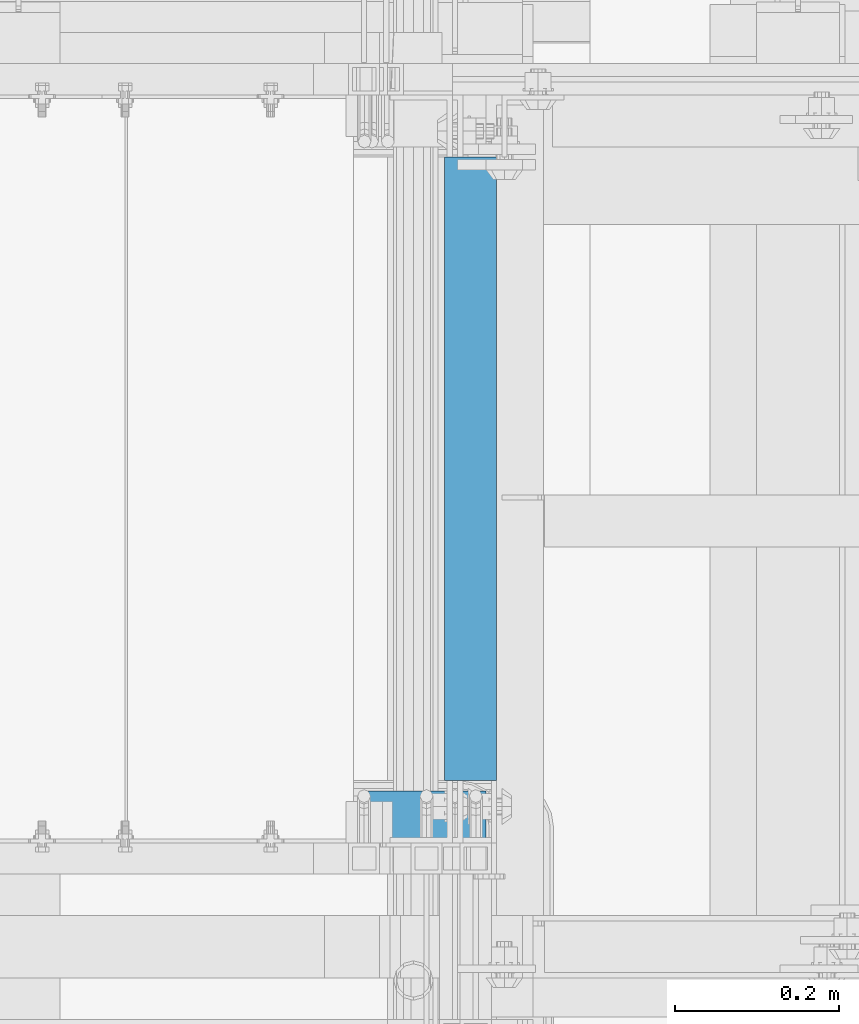
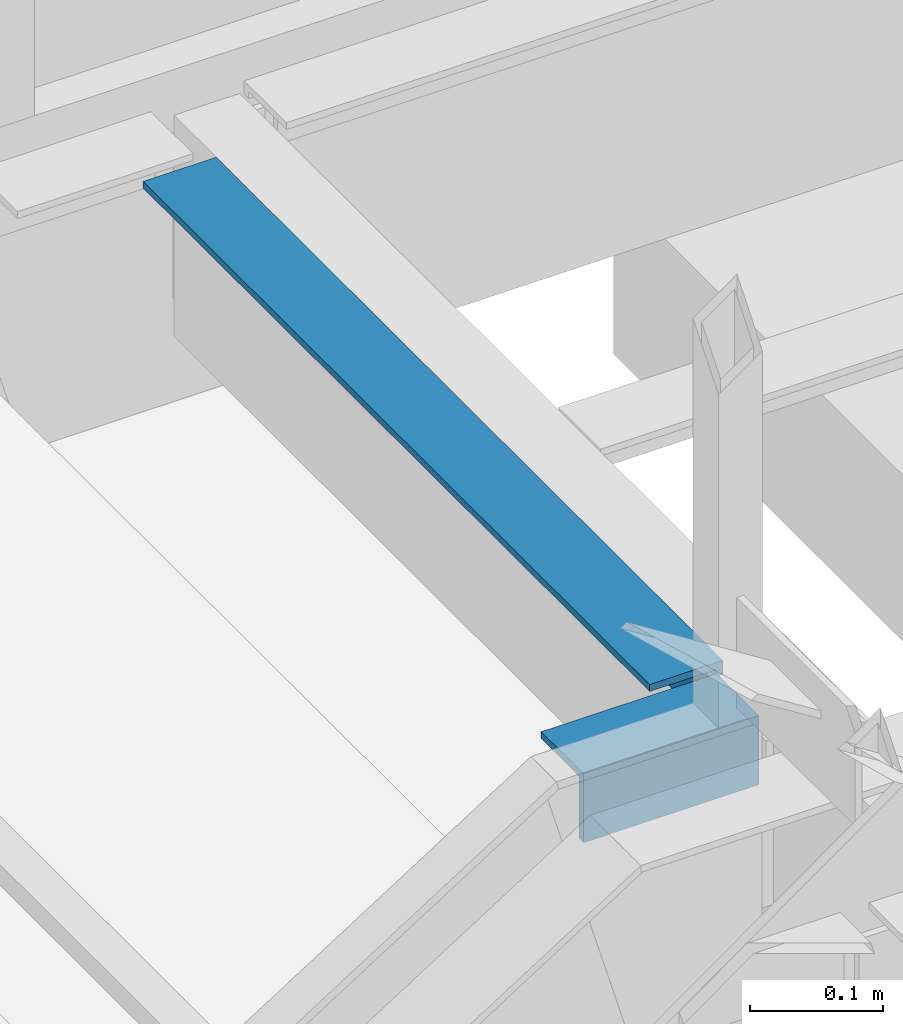
# One storey, part 1195 of 1876: 2 beams, 2 elements without a shape of their own.
"""IFC2X3 building model written with IfcOpenShell, lengths in millimetres."""

import ifcopenshell
import ifcopenshell.guid

model = None  # the IFC model being written
_history = None  # IfcOwnerHistory: only IFC2X3 demands one
_inside = {}  # id of a spatial element -> (the spatial element, [elements in it])
_under = {}  # id of a project, library or spatial element -> (it, [spatial elements below it])
_declared = {}  # id of a project -> (the project, [libraries it declares])
_typed = {}  # id of a type object -> (the type object, [elements of that type])
_made_of = {}  # id of a material, layer set ... -> (it, [elements and type objects made of it])


def new_model(schema):
    """Start an empty IFC model of exactly this schema.

    Asked for "IFC4X3", IfcOpenShell would pick the latest addendum, in which some entities
    have other attributes; the version numbers below select the first issue.
    IFC2X3 requires an IfcOwnerHistory on every rooted entity: one is made here for all.
    """
    global model, _history
    if schema == "IFC4X3":
        model = ifcopenshell.file(schema_version=(4, 3, 0, 0))
    else:
        model = ifcopenshell.file(schema=schema)
    _inside.clear()
    _under.clear()
    _declared.clear()
    _typed.clear()
    _made_of.clear()
    _history = None
    if model.schema == "IFC2X3":
        org = make("IfcOrganization", Name="unknown")
        user = make(
            "IfcPersonAndOrganization",
            ThePerson=make("IfcPerson", FamilyName="unknown"),
            TheOrganization=org,
        )
        app = make(
            "IfcApplication",
            ApplicationDeveloper=org,
            Version="unknown",
            ApplicationFullName="unknown",
            ApplicationIdentifier="unknown",
        )
        _history = make(
            "IfcOwnerHistory",
            OwningUser=user,
            OwningApplication=app,
            ChangeAction="ADDED",
            CreationDate=0,
        )
    return model


def make(cls, **values):
    """One entity of the class cls with the attributes given. An attribute that is None is left unset."""
    return model.create_entity(
        cls, **{name: value for name, value in values.items() if value is not None}
    )


def rooted(cls, **values):
    """An entity with a GlobalId (a new one), such as an element, a storey or a relation."""
    return make(cls, GlobalId=ifcopenshell.guid.new(), OwnerHistory=_history, **values)


def si_unit(unit_type, name, prefix=None):
    """IfcSIUnit, for example si_unit("LENGTHUNIT", "METRE", prefix="MILLI")."""
    return make("IfcSIUnit", UnitType=unit_type, Prefix=prefix, Name=name)


def assignment(units):
    """IfcUnitAssignment: the units of a project."""
    return None if units is None else make("IfcUnitAssignment", Units=units)


def point(xyz):
    """IfcCartesianPoint."""
    return None if xyz is None else make("IfcCartesianPoint", Coordinates=xyz)


def direction(xyz):
    """IfcDirection."""
    return None if xyz is None else make("IfcDirection", DirectionRatios=xyz)


def frame(location, z_axis=None, x_axis=None):
    """IfcAxis2Placement3D, a coordinate frame: its origin and axes. An axis left out is left unset."""
    return make(
        "IfcAxis2Placement3D",
        Location=point(location),
        Axis=direction(z_axis),
        RefDirection=direction(x_axis),
    )


def origin_with_axes():
    """The frame at (0, 0, 0) with the z axis (0, 0, 1) and the x axis (1, 0, 0) written out."""
    return frame((0.0, 0.0, 0.0), z_axis=(0.0, 0.0, 1.0), x_axis=(1.0, 0.0, 0.0))


def place(relative_to, where):
    """IfcLocalPlacement: puts the frame where relative to a parent placement (None: the world)."""
    return make(
        "IfcLocalPlacement", PlacementRelTo=relative_to, RelativePlacement=where
    )


def context(
    kind, dimensions, precision=None, world=None, true_north=None, identifier=None
):
    """IfcGeometricRepresentationContext, for example the 3D "Model" context."""
    return make(
        "IfcGeometricRepresentationContext",
        ContextIdentifier=identifier,
        ContextType=kind,
        CoordinateSpaceDimension=dimensions,
        Precision=precision,
        WorldCoordinateSystem=world,
        TrueNorth=true_north,
    )


def subcontext(parent, identifier, kind, view, scale=None):
    """IfcGeometricRepresentationSubContext, for example "Body" below "Model"."""
    return make(
        "IfcGeometricRepresentationSubContext",
        ContextIdentifier=identifier,
        ContextType=kind,
        ParentContext=parent,
        TargetScale=scale,
        TargetView=view,
    )


def project(units=None, contexts=None):
    """IfcProject with its units and contexts."""
    return rooted(
        "IfcProject",
        Name="project",
        RepresentationContexts=contexts,
        UnitsInContext=assignment(units),
    )


def spatial(cls, under=None, at=None, **own):
    """A site, building, storey or space (cls), placed at a placement, below another one or the project."""
    s = rooted(cls, ObjectPlacement=at, **own)
    if under is not None:
        _under.setdefault(under.id(), (under, []))[1].append(s)
    return s


def faces_of(points, faces, orient=None, outer=None):
    """IfcFace entities. A face is a list of loops; a loop is a list of indices into points, from 0.

    orient and outer hold one flag for each loop. By default every Orientation is true, the
    first loop of a face is its IfcFaceOuterBound and the others are IfcFaceBound.
    """
    made = []
    for i, loops in enumerate(faces):
        bounds = []
        for j, loop in enumerate(loops):
            is_outer = j == 0 if outer is None else outer[i][j]
            bounds.append(
                make(
                    "IfcFaceOuterBound" if is_outer else "IfcFaceBound",
                    Bound=make("IfcPolyLoop", Polygon=[points[k] for k in loop]),
                    Orientation=True if orient is None else orient[i][j],
                )
            )
        made.append(make("IfcFace", Bounds=bounds))
    return made


def faceted_brep(points, faces, orient=None, outer=None, voids=None):
    """IfcFacetedBrep: a solid bounded by flat faces; with voids (closed shells), ...WithVoids."""
    shared = [point(p) for p in points]
    hull = make("IfcClosedShell", CfsFaces=faces_of(shared, faces, orient, outer))
    if voids is None:
        return make("IfcFacetedBrep", Outer=hull)
    return make(
        "IfcFacetedBrepWithVoids",
        Outer=hull,
        Voids=[
            make(cls, CfsFaces=faces_of(shared, fs, o, b)) for cls, fs, o, b in voids
        ],
    )


def shape(context_of_items, identifier, shape_type, items):
    """IfcShapeRepresentation: the items that make up one representation, for example the "Body"."""
    return make(
        "IfcShapeRepresentation",
        ContextOfItems=context_of_items,
        RepresentationIdentifier=identifier,
        RepresentationType=shape_type,
        Items=items,
    )


def material(Name=None, Category=None):
    """IfcMaterial."""
    return make("IfcMaterial", Name=Name, Category=Category)


def made_of(thing, what):
    """Note that an element or type object is made of a material, layer set ...; save() writes the relation."""
    if what is not None:
        _made_of.setdefault(what.id(), (what, []))[1].append(thing)
    return thing


def type_object(cls, material=None, **own):
    """A type object (cls), such as IfcWallType, which elements share."""
    return made_of(rooted(cls, **own), material)


def element(
    cls,
    number,
    at=None,
    inside=None,
    cuts=None,
    type_object=None,
    material=None,
    context=None,
    identifier="Body",
    shape_type=None,
    held_by="IfcProductDefinitionShape",
    body=None,
    shapes=None,
    **own,
):
    """One element of the class cls, such as IfcWall. Its Tag is "e" and its number.

    at: its placement. inside: the storey or other place that contains it. cuts: it is an
    opening in that element (IfcRelVoidsElement). A single representation is given by context,
    identifier, shape_type and body (its items); several are given by shapes. held_by: the class
    of the entity that holds the representations. save() writes the other relations.
    """
    e = rooted(cls, Tag="e%d" % number, ObjectPlacement=at, **own)
    if body is not None:
        shapes = [shape(context, identifier, shape_type, body)]
    if shapes is not None:
        e.Representation = make(held_by, Representations=shapes)
    if inside is not None:
        _inside.setdefault(inside.id(), (inside, []))[1].append(e)
    if cuts is not None:
        rooted(
            "IfcRelVoidsElement", RelatingBuildingElement=cuts, RelatedOpeningElement=e
        )
    if type_object is not None:
        _typed.setdefault(type_object.id(), (type_object, []))[1].append(e)
    return made_of(e, material)


def aggregate(whole, parts):
    """IfcRelAggregates: a whole, such as a stair, and the parts it consists of."""
    return rooted("IfcRelAggregates", RelatingObject=whole, RelatedObjects=parts)


def save(model, path):
    """Write the relations noted so far, then the file.

    IfcRelAggregates (storeys below a building ...), IfcRelContainedInSpatialStructure (elements
    in a storey), IfcRelDefinesByType, IfcRelAssociatesMaterial and IfcRelDeclares: one each for
    every whole, place, type object, material and project.
    """
    for whole, parts in _under.values():
        aggregate(whole, parts)
    for where, things in _inside.values():
        rooted(
            "IfcRelContainedInSpatialStructure",
            RelatedElements=things,
            RelatingStructure=where,
        )
    for kind, things in _typed.values():
        rooted("IfcRelDefinesByType", RelatedObjects=things, RelatingType=kind)
    for what, things in _made_of.values():
        rooted("IfcRelAssociatesMaterial", RelatedObjects=things, RelatingMaterial=what)
    for by, libraries in _declared.values():
        rooted("IfcRelDeclares", RelatingContext=by, RelatedDefinitions=libraries)
    model.write(path)


model = new_model("IFC2X3")

# Units and contexts
model_context = context("Model", 3, precision=1e-05, world=origin_with_axes())
body_context = subcontext(model_context, "Body", "Model", "MODEL_VIEW")
ifc_project = project(units=[si_unit("LENGTHUNIT", "METRE", prefix="MILLI"), si_unit("AREAUNIT", "SQUARE_METRE"), si_unit("VOLUMEUNIT", "CUBIC_METRE"), si_unit("MASSUNIT", "GRAM", prefix="KILO"), si_unit("TIMEUNIT", "SECOND"), si_unit("PLANEANGLEUNIT", "RADIAN"), si_unit("SOLIDANGLEUNIT", "STERADIAN"), si_unit("THERMODYNAMICTEMPERATUREUNIT", "DEGREE_CELSIUS"), si_unit("LUMINOUSINTENSITYUNIT", "LUMEN")], contexts=[model_context])

# Site, building, storey
site_placement = place(None, origin_with_axes())
site = spatial("IfcSite", under=ifc_project, at=site_placement, CompositionType="ELEMENT")
building_placement = place(site_placement, origin_with_axes())
building = spatial("IfcBuilding", under=site, at=building_placement, Name="Undefined", CompositionType="ELEMENT")
storey_placement = place(building_placement, origin_with_axes())
storey = spatial("IfcBuildingStorey", under=building, at=storey_placement, Name="Undefined", CompositionType="ELEMENT", Elevation=0.0)

# Assembly, beam
assembly_1_placement = place(storey_placement, origin_with_axes())
assembly_1 = element("IfcElementAssembly", 1, at=assembly_1_placement, inside=storey, Name="STRINGER", AssemblyPlace="NOTDEFINED", PredefinedType="RIGID_FRAME")
ifc_material = material(Name="STEEL/A36")
beam_type = type_object("IfcBeamType", Name="L2-1/2X2-1/2X1/4", PredefinedType="NOTDEFINED")
beam_1_placement = place(assembly_1_placement, frame((6267.44999998667, -5638.80002070451, 2266.27952216669), z_axis=(0.0, 0.0, -1.0), x_axis=(0.0, 1.0, 0.0)))
beam_1 = element("IfcBeam", 2, at=beam_1_placement, type_object=beam_type, material=ifc_material, Name="STRINGER", ObjectType="L2-1/2X2-1/2X1/4", context=body_context, shape_type="Brep", body=[
    faceted_brep([(12.7000026066708, 25.3999999999996, -19.0494857698618), (12.7000026066708, 31.75, -19.0494857698618), (-9.09494701772928e-12, 31.75, -19.0494770703599), (-9.09494701772928e-12, 25.3999999999996, -19.0494770703599), (12.7000374046956, 25.3999999999996, 31.7505134671646), (12.6999938957251, 31.75, 31.75), (0.0, 25.3999999999996, -25.3999999999996), (0.0, -31.75, -25.3999999999996), (762.000002272681, -31.75, -25.3999999999996), (762.000002272681, 25.4000000000001, -25.3999999999996), (0.0, -31.75, -31.75), (762.000002272681, -31.75, -31.75), (0.0, 31.75, -31.75), (762.000002272681, 31.75, -31.75), (761.999997745727, 25.3999999999996, 31.7500000000168), (761.999997745727, 31.75, 31.7500000000168)], [[[0, 1, 2, 3]], [[4, 5, 1, 0]], [[6, 7, 8, 9]], [[7, 10, 11, 8]], [[10, 12, 13, 11]], [[14, 9, 8, 11, 13, 15]], [[3, 6, 9, 14, 4, 0]], [[12, 10, 7, 6, 3, 2]], [[15, 13, 12, 2, 1, 5]], [[14, 15, 5, 4]]]),
])
aggregate(assembly_1, [beam_1])

assembly_2_placement = place(storey_placement, origin_with_axes())
assembly_2 = element("IfcElementAssembly", 3, at=assembly_2_placement, inside=storey, Name="STRINGER", AssemblyPlace="NOTDEFINED", PredefinedType="RIGID_FRAME")
beam_2_placement = place(assembly_2_placement, frame((6286.50000038044, -5683.25000121455, 2266.27941773333), z_axis=(0.0, 1.0, 0.0), x_axis=(-1.0, 0.0, 0.0)))
beam_2 = element("IfcBeam", 4, at=beam_2_placement, type_object=beam_type, material=ifc_material, Name="ANGLE", ObjectType="L2-1/2X2-1/2X1/4", context=body_context, shape_type="Brep", body=[
    faceted_brep([(0.0, 31.75, -31.75), (0.0, 31.75, 31.75), (152.400073242188, 31.75, 31.75), (152.400073242188, 31.75, -31.75), (0.0, 25.3999999999996, 31.75), (152.400073242188, 25.3999999999996, 31.75), (0.0, 25.3999999999996, -25.3999999999996), (152.400073242188, 25.3999999999996, -25.3999999999996), (0.0, -31.75, -25.3999999999996), (152.400073242188, -31.75, -25.3999999999996), (0.0, -31.75, -31.75), (152.400073242188, -31.75, -31.75)], [[[0, 1, 2, 3]], [[1, 4, 5, 2]], [[4, 6, 7, 5]], [[6, 8, 9, 7]], [[8, 10, 11, 9]], [[10, 0, 3, 11]], [[5, 7, 9, 11, 3, 2]], [[10, 8, 6, 4, 1, 0]]]),
])
aggregate(assembly_2, [beam_2])

save(model, "model.ifc")
